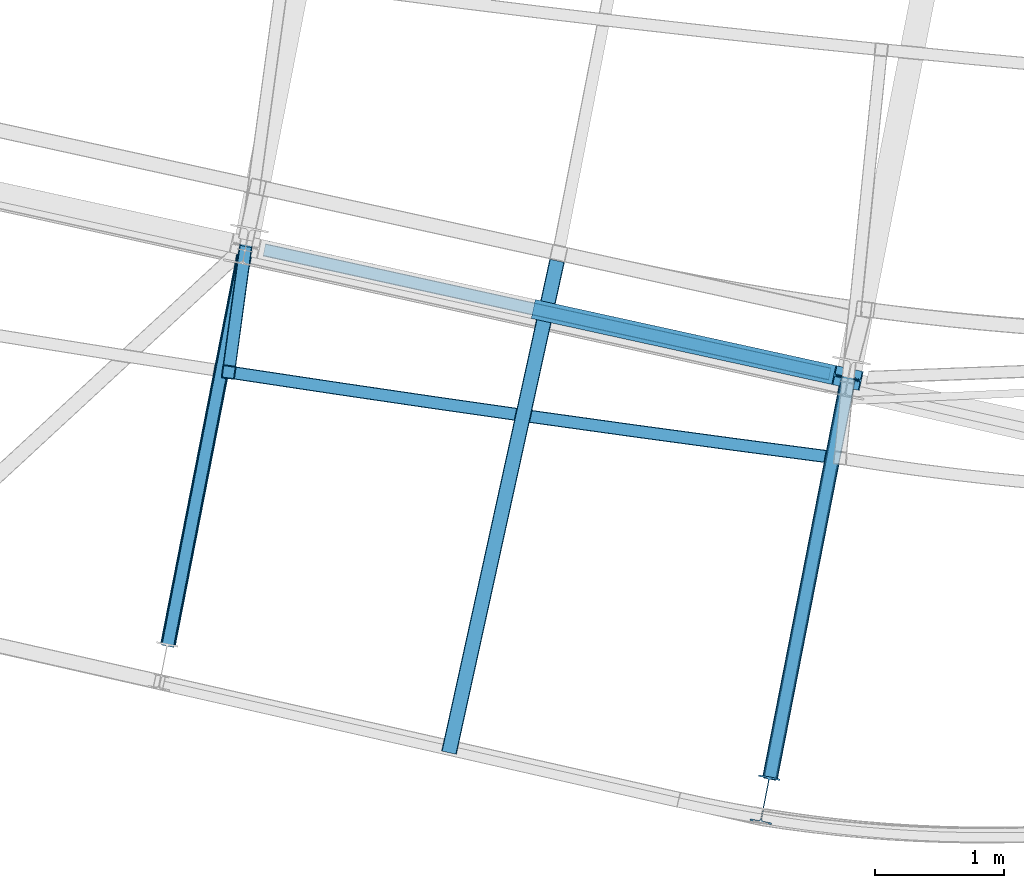
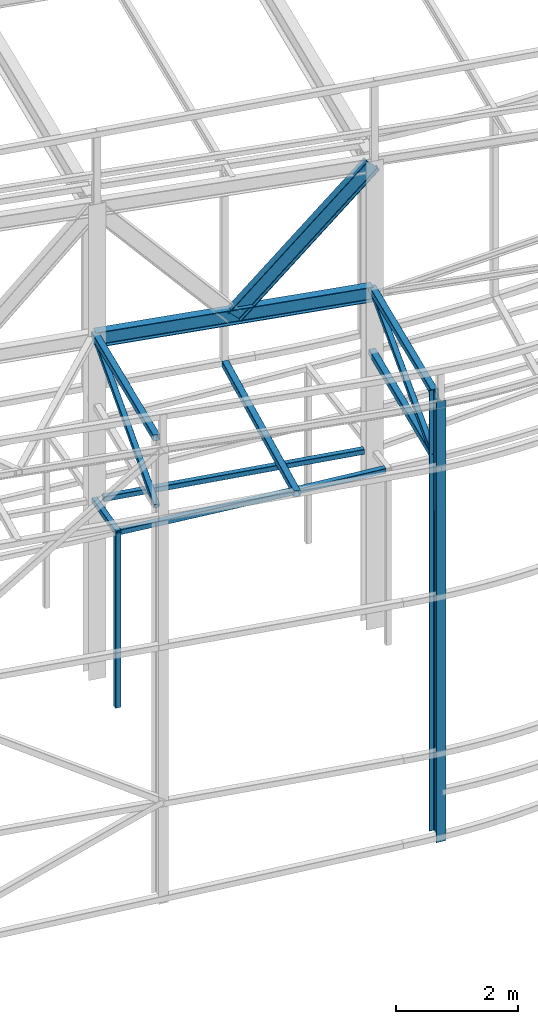
# One storey, part 46 of 215: 10 beams, 3 members, 13 elements without a shape of their own.
"""IFC2X3 building model written with IfcOpenShell, lengths in millimetres."""

from ifc_helpers import new_model, entity, si_unit, frame, origin_with_axes, origin_2d_with_axis, place, context, subcontext, project, spatial, hollow_rectangle, i_section, extrude, clip, halfspace, material, type_object, element, aggregate, save


model = new_model("IFC2X3")

# Units and contexts
model_context = context("Model", 3, precision=1e-05, world=origin_with_axes())
body_context = subcontext(model_context, "Body", "Model", "MODEL_VIEW")
ifc_project = project(units=[si_unit("LENGTHUNIT", "METRE", prefix="MILLI"), si_unit("AREAUNIT", "SQUARE_METRE"), si_unit("VOLUMEUNIT", "CUBIC_METRE"), si_unit("MASSUNIT", "GRAM", prefix="KILO"), si_unit("TIMEUNIT", "SECOND"), si_unit("PLANEANGLEUNIT", "RADIAN"), si_unit("SOLIDANGLEUNIT", "STERADIAN"), si_unit("THERMODYNAMICTEMPERATUREUNIT", "DEGREE_CELSIUS"), si_unit("LUMINOUSINTENSITYUNIT", "LUMEN")], contexts=[model_context])

# Site, building, storey
site_placement = place(None, origin_with_axes())
site = spatial("IfcSite", under=ifc_project, at=site_placement, CompositionType="ELEMENT")
building_placement = place(site_placement, origin_with_axes())
building = spatial("IfcBuilding", under=site, at=building_placement, Name="Undefined", CompositionType="ELEMENT")
storey_placement = place(building_placement, origin_with_axes())
storey = spatial("IfcBuildingStorey", under=building, at=storey_placement, Name="Undefined", CompositionType="ELEMENT", Elevation=0.0)

# Assembly, beam
assembly_1_placement = place(storey_placement, origin_with_axes())
assembly_1 = element("IfcElementAssembly", 1, at=assembly_1_placement, inside=storey, Name="Steel Assembly", AssemblyPlace="NOTDEFINED", PredefinedType="RIGID_FRAME")
ifc_material = material(Name="STEEL/S275JR")
beam_type_1 = type_object("IfcBeamType", PredefinedType="NOTDEFINED")
beam_1_placement = place(assembly_1_placement, frame((69594.1039692356, 4800.26611499706, 6760.00000147687), z_axis=(0.214484663892396, 0.976727356509976, 0.0), x_axis=(0.976727356509977, -0.214484663892393, 0.0)))
beam_1 = element("IfcBeam", 2, at=beam_1_placement, type_object=beam_type_1, material=ifc_material, Name="POUTRE", context=body_context, shape_type="Clipping", body=[
    clip(clip(extrude(hollow_rectangle(XDim=100.0, YDim=100.0, WallThickness=4.0, InnerFilletRadius=4.0, OuterFilletRadius=8.0, at=origin_2d_with_axis()), frame((4673.24731057957, 0.0, 1.29708669099326e-13), z_axis=(-1.0, 0.0, 0.0), x_axis=(-6.93889390390723e-18, -1.0, -3.46944695195361e-18)), (0.0, 0.0, 1.0), 4568.4), halfspace(frame((4634.73255336854, -50.0, -72.833586639008), z_axis=(0.999733029085594, 0.0, 0.0231056390377605), x_axis=(-6.93889390390723e-18, -1.0, -3.46944695195361e-18)), False)), halfspace(frame((147.020154555328, -50.0, -86.8364912245997), z_axis=(0.999733029085594, 0.0, 0.0231056390377605), x_axis=(-6.93889390390723e-18, -1.0, -3.46944695195361e-18)), True)),
])
aggregate(assembly_1, [beam_1])

assembly_2_placement = place(storey_placement, origin_with_axes())
assembly_2 = element("IfcElementAssembly", 3, at=assembly_2_placement, inside=storey, Name="Steel Assembly", AssemblyPlace="NOTDEFINED", PredefinedType="RIGID_FRAME")
beam_2_placement = place(assembly_2_placement, frame((69510.3835750378, 3814.91252455301, 6760.00000147687), z_axis=(0.139740681937078, 0.990188134554116, 0.0), x_axis=(0.990188134554117, -0.139740681937074, 0.0)))
beam_2 = element("IfcBeam", 4, at=beam_2_placement, type_object=beam_type_1, material=ifc_material, Name="POUTRE", context=body_context, shape_type="SweptSolid", body=[
    entity("IfcRevolvedAreaSolid", entity("IfcRectangleHollowProfileDef", "AREA", None, entity("IfcAxis2Placement2D", entity("IfcCartesianPoint", [0.0, 0.0]), entity("IfcDirection", [1.0, 0.0])), 100.0, 100.0, 4.0, 4.0, 8.0), entity("IfcAxis2Placement3D", entity("IfcCartesianPoint", [4685.45059726036, 0.0, 0.0]), entity("IfcDirection", [-0.999937742095263, 0.0, -0.0111584915390816]), entity("IfcDirection", [-6.93889390390723e-18, -1.0, -3.46944695195361e-18])), entity("IfcAxis1Placement", entity("IfcCartesianPoint", [0.0, 209950.0, 0.0]), entity("IfcDirection", [-1.0, 0.0, 0.0])), 0.0223174462258958),
])
aggregate(assembly_2, [beam_2])

assembly_3_placement = place(storey_placement, origin_with_axes())
assembly_3 = element("IfcElementAssembly", 5, at=assembly_3_placement, inside=storey, Name="Steel Assembly", AssemblyPlace="NOTDEFINED", PredefinedType="RIGID_FRAME")
beam_3_placement = place(assembly_3_placement, frame((69460.0917916499, 3821.80226042319, 6760.00000147429), z_axis=(-0.990749114285665, 0.135706273039128, 0.0), x_axis=(0.0, 0.0, -1.0)))
beam_3 = element("IfcBeam", 6, at=beam_3_placement, type_object=beam_type_1, material=ifc_material, Name="MONTANT", context=body_context, shape_type="SweptSolid", body=[
    extrude(hollow_rectangle(XDim=100.0, YDim=100.0, WallThickness=4.0, InnerFilletRadius=4.0, OuterFilletRadius=8.0, at=origin_2d_with_axis()), frame((3499.99999998675, 0.0, 0.0), z_axis=(-1.0, 0.0, 0.0), x_axis=(-6.93889390390723e-18, -1.0, -3.46944695195361e-18)), (0.0, 0.0, 1.0), 3500.0),
])
aggregate(assembly_3, [beam_3])

assembly_4_placement = place(storey_placement, origin_with_axes())
assembly_4 = element("IfcElementAssembly", 7, at=assembly_4_placement, inside=storey, Name="Steel Assembly", AssemblyPlace="NOTDEFINED", PredefinedType="RIGID_FRAME")
beam_4_placement = place(assembly_4_placement, frame((69453.307008648, 3772.26868029184, 6760.00000147687), z_axis=(-0.990759727875758, 0.135628763982991, 0.0), x_axis=(0.135628763982999, 0.990759727875757, 0.0)))
beam_4 = element("IfcBeam", 8, at=beam_4_placement, type_object=beam_type_1, material=ifc_material, Name="POUTRE", context=body_context, shape_type="Clipping", body=[
    clip(extrude(hollow_rectangle(XDim=100.0, YDim=100.0, WallThickness=4.0, InnerFilletRadius=4.0, OuterFilletRadius=8.0, at=origin_2d_with_axis()), frame((1062.75482662003, 0.0, 0.0), z_axis=(-1.0, 0.0, 0.0), x_axis=(-6.93889390390723e-18, -1.0, -3.46944695195361e-18)), (0.0, 0.0, 1.0), 1062.8), halfspace(frame((1028.36267516113, -50.0, -78.3644538667868), z_axis=(0.99837545974863, 0.0, -0.0569775514717144), x_axis=(-6.93889390390723e-18, -1.0, -3.46944695195361e-18)), False)),
])
aggregate(assembly_4, [beam_4])

assembly_5_placement = place(storey_placement, origin_with_axes())
assembly_5 = element("IfcElementAssembly", 9, at=assembly_5_placement, inside=storey, Name="Steel Assembly", AssemblyPlace="NOTDEFINED", PredefinedType="RIGID_FRAME")
beam_type_2 = type_object("IfcBeamType", PredefinedType="NOTDEFINED")
beam_5_placement = place(assembly_5_placement, frame((72005.1935586869, 4684.79461828845, 8706.00016021823), z_axis=(0.976696868550088, -0.214623453901133, -1.0000003380751e-09), x_axis=(-0.214623453901134, -0.976696868550088, 0.0)))
beam_5 = element("IfcBeam", 10, at=beam_5_placement, type_object=beam_type_2, material=ifc_material, Name="LISSE", context=body_context, shape_type="SweptSolid", body=[
    extrude(hollow_rectangle(XDim=120.0, YDim=120.0, WallThickness=5.0, InnerFilletRadius=5.0, OuterFilletRadius=10.0, at=origin_2d_with_axis()), frame((3902.74522563965, -2.01767199148938e-22, 1.08322940218776e-13), z_axis=(-1.0, 0.0, 0.0), x_axis=(-6.93889390390723e-18, -1.0, -3.46944695195361e-18)), (0.0, 0.0, 1.0), 3902.7),
])
aggregate(assembly_5, [beam_5])

assembly_6_placement = place(storey_placement, origin_with_axes())
assembly_6 = element("IfcElementAssembly", 11, at=assembly_6_placement, inside=storey, Name="Steel Assembly", AssemblyPlace="NOTDEFINED", PredefinedType="RIGID_FRAME")
beam_6_placement = place(assembly_6_placement, frame((74260.993191298, 3775.43952138853, 8710.00002372329), z_axis=(0.0, 0.0, 1.0), x_axis=(-0.191859508000518, -0.981422401002646, -1.00000033853845e-09)))
beam_6 = element("IfcBeam", 12, at=beam_6_placement, type_object=beam_type_2, material=ifc_material, Name="POUTRE", context=body_context, shape_type="SweptSolid", body=[
    extrude(hollow_rectangle(XDim=120.0, YDim=120.0, WallThickness=5.0, InnerFilletRadius=5.0, OuterFilletRadius=10.0, at=origin_2d_with_axis()), frame((3149.71743913705, 6.04302930320082e-16, 0.0), z_axis=(-1.0, 0.0, 0.0), x_axis=(-6.93889390390723e-18, -1.0, -3.46944695195361e-18)), (0.0, 0.0, 1.0), 3149.7),
])
aggregate(assembly_6, [beam_6])

assembly_7_placement = place(storey_placement, origin_with_axes())
assembly_7 = element("IfcElementAssembly", 13, at=assembly_7_placement, inside=storey, Name="Steel Assembly", AssemblyPlace="NOTDEFINED", PredefinedType="RIGID_FRAME")
beam_7_placement = place(assembly_7_placement, frame((73656.690666197, 684.236178870427, 9980.29846890586), z_axis=(-0.981422412140383, 0.191859451027444, 0.0), x_axis=(0.191859470081235, 0.981422408415534, 0.0)))
beam_7 = element("IfcBeam", 14, at=beam_7_placement, type_object=beam_type_2, material=ifc_material, context=body_context, shape_type="SweptSolid", body=[
    extrude(hollow_rectangle(XDim=120.0, YDim=120.0, WallThickness=5.0, InnerFilletRadius=5.0, OuterFilletRadius=10.0, at=origin_2d_with_axis()), frame((3149.71743913705, 6.04302930320082e-16, 0.0), z_axis=(-1.0, 0.0, 0.0), x_axis=(-6.93889390390723e-18, -1.0, -3.46944695195361e-18)), (0.0, 0.0, 1.0), 3149.7),
])
aggregate(assembly_7, [beam_7])

assembly_8_placement = place(storey_placement, origin_with_axes())
assembly_8 = element("IfcElementAssembly", 15, at=assembly_8_placement, inside=storey, Name="Steel Assembly", AssemblyPlace="NOTDEFINED", PredefinedType="RIGID_FRAME")
beam_8_placement = place(assembly_8_placement, frame((68991.3141226545, 1716.93443117377, 10075.4986663759), z_axis=(-0.981422412140383, 0.191859451027444, 0.0), x_axis=(0.191859470081235, 0.981422408415534, 0.0)))
beam_8 = element("IfcBeam", 16, at=beam_8_placement, type_object=beam_type_2, material=ifc_material, context=body_context, shape_type="SweptSolid", body=[
    extrude(hollow_rectangle(XDim=120.0, YDim=120.0, WallThickness=5.0, InnerFilletRadius=5.0, OuterFilletRadius=10.0, at=origin_2d_with_axis()), frame((3141.19707134942, 0.0, 8.7185732837431e-14), z_axis=(-1.0, 0.0, 0.0), x_axis=(-6.93889390390723e-18, -1.0, -3.46944695195361e-18)), (0.0, 0.0, 1.0), 3141.2),
])
aggregate(assembly_8, [beam_8])

# Assembly, member
assembly_9_placement = place(storey_placement, origin_with_axes())
assembly_9 = element("IfcElementAssembly", 17, at=assembly_9_placement, inside=storey, Name="Steel Assembly", AssemblyPlace="NOTDEFINED", PredefinedType="RIGID_FRAME")
member_type_1 = type_object("IfcMemberType", PredefinedType="NOTDEFINED")
member_1_placement = place(assembly_9_placement, frame((74260.994035234, 3775.43935559565, 9980.29846550876), z_axis=(-0.981585932424495, 0.191009013082603, 0.00214806600092869), x_axis=(-0.177933778017051, -0.910186621087223, -0.374031931035844)))
member_1 = element("IfcMember", 18, at=member_1_placement, type_object=member_type_1, material=ifc_material, context=body_context, shape_type="SweptSolid", body=[
    extrude(hollow_rectangle(XDim=100.0, YDim=100.0, WallThickness=5.0, InnerFilletRadius=5.0, OuterFilletRadius=10.0, at=origin_2d_with_axis()), frame((3396.22993168259, -2.00751803689961e-12, 9.8682956521107e-14), z_axis=(-1.0, 0.0, 0.0), x_axis=(-6.93889390390723e-18, -1.0, -3.46944695195361e-18)), (0.0, 0.0, 1.0), 3396.2),
])
aggregate(assembly_9, [member_1])

assembly_10_placement = place(storey_placement, origin_with_axes())
assembly_10 = element("IfcElementAssembly", 19, at=assembly_10_placement, inside=storey, Name="Steel Assembly", AssemblyPlace="NOTDEFINED", PredefinedType="RIGID_FRAME")
member_2_placement = place(assembly_10_placement, frame((69593.1668340665, 4795.60342098526, 10081.2819122802), z_axis=(-0.981393164856902, 0.192008684972003, -0.000347659999948757), x_axis=(-0.175796815929142, -0.899256439637532, -0.400541302838552)))
member_2 = element("IfcMember", 20, at=member_2_placement, type_object=member_type_1, material=ifc_material, context=body_context, shape_type="SweptSolid", body=[
    extrude(hollow_rectangle(XDim=100.0, YDim=100.0, WallThickness=5.0, InnerFilletRadius=5.0, OuterFilletRadius=10.0, at=origin_2d_with_axis()), frame((3423.57174035155, 2.00903581217557e-12, -5.2615387545434e-14), z_axis=(-1.0, 0.0, 0.0), x_axis=(-6.93889390390723e-18, -1.0, -3.46944695195361e-18)), (0.0, 0.0, 1.0), 3423.6),
])
aggregate(assembly_10, [member_2])

# Assembly, beam
assembly_11_placement = place(storey_placement, origin_with_axes())
assembly_11 = element("IfcElementAssembly", 21, at=assembly_11_placement, inside=storey, Name="Steel Assembly", AssemblyPlace="NOTDEFINED", PredefinedType="RIGID_FRAME")
beam_type_3 = type_object("IfcBeamType", Name="IPE300", PredefinedType="NOTDEFINED")
beam_9_placement = place(assembly_11_placement, frame((74259.0660443935, 3775.88718848575, 9901.01159606102), z_axis=(-0.0185774880042807, 0.00410459700094685, -0.999818998230635), x_axis=(-0.976570183321219, 0.214356495070507, 0.0190255110062579)))
beam_9 = element("IfcBeam", 22, at=beam_9_placement, type_object=beam_type_3, material=ifc_material, Name="POUTRE", ObjectType="IPE300", context=body_context, shape_type="SweptSolid", body=[
    extrude(i_section(OverallWidth=150.0, OverallDepth=300.0, WebThickness=7.099999905, FlangeThickness=10.69999981, FilletRadius=15.0, at=origin_2d_with_axis()), frame((4775.96148532888, 1.54072979968892e-13, 3.31398900358442e-14), z_axis=(-1.0, 0.0, 0.0), x_axis=(-6.93889390390723e-18, -1.0, -3.46944695195361e-18)), (0.0, 0.0, 1.0), 4776.0),
])
aggregate(assembly_11, [beam_9])

assembly_12_placement = place(storey_placement, origin_with_axes())
assembly_12 = element("IfcElementAssembly", 23, at=assembly_12_placement, inside=storey, Name="Steel Assembly", AssemblyPlace="NOTDEFINED", PredefinedType="RIGID_FRAME")
beam_type_4 = type_object("IfcBeamType", Name="IPE360", PredefinedType="NOTDEFINED")
beam_10_placement = place(assembly_12_placement, frame((73616.3238805302, 508.720262564695, 10040.2984687938), z_axis=(0.191859470081235, 0.981422408415534, 0.0), x_axis=(0.0, 0.0, -1.0)))
beam_10 = element("IfcBeam", 24, at=beam_10_placement, type_object=beam_type_4, material=ifc_material, Name="MONTANT", ObjectType="IPE360", context=body_context, shape_type="Clipping", body=[
    clip(extrude(i_section(OverallWidth=170.0, OverallDepth=360.0, WebThickness=8.0, FlangeThickness=12.69999981, FilletRadius=18.0, at=origin_2d_with_axis()), frame((8825.51106143926, 1.45519152283669e-11, 0.0), z_axis=(-1.0, 0.0, 0.0), x_axis=(-6.93889390390723e-18, -1.0, -3.46944695195361e-18)), (0.0, 0.0, 1.0), 8825.5), halfspace(frame((8825.57926863576, 112.092476811085, -652.500200287432), z_axis=(-0.998865278233528, 0.0476041146550479, 0.00141570030935933), x_axis=(-1.0230287445127e-09, -0.0297259118404429, 0.999558087439271)), True)),
])
aggregate(assembly_12, [beam_10])

# Assembly, member
assembly_13_placement = place(storey_placement, origin_with_axes())
assembly_13 = element("IfcElementAssembly", 25, at=assembly_13_placement, inside=storey, Name="Steel Assembly", AssemblyPlace="NOTDEFINED", PredefinedType="RIGID_FRAME")
member_type_2 = type_object("IfcMemberType", Name="IPE300", PredefinedType="NOTDEFINED")
member_3_placement = place(assembly_13_placement, frame((71927.0339488053, 4287.70695095298, 9946.4439318402), z_axis=(0.710164382072086, -0.155910956015825, -0.686555405069688), x_axis=(0.670593118056704, -0.147184221012446, 0.72707748906148)))
member_3 = element("IfcMember", 26, at=member_3_placement, type_object=member_type_2, material=ifc_material, Name="POUTRE", ObjectType="IPE300", context=body_context, shape_type="SweptSolid", body=[
    extrude(i_section(OverallWidth=150.0, OverallDepth=300.0, WebThickness=7.099999905, FlangeThickness=10.69999981, FilletRadius=15.0, at=origin_2d_with_axis()), frame((3473.59685038519, 3.58361777802671e-12, 1.92823360078153e-13), z_axis=(-1.0, 0.0, 0.0), x_axis=(-6.93889390390723e-18, -1.0, -3.46944695195361e-18)), (0.0, 0.0, 1.0), 3473.6),
])
aggregate(assembly_13, [member_3])

save(model, "model.ifc")
